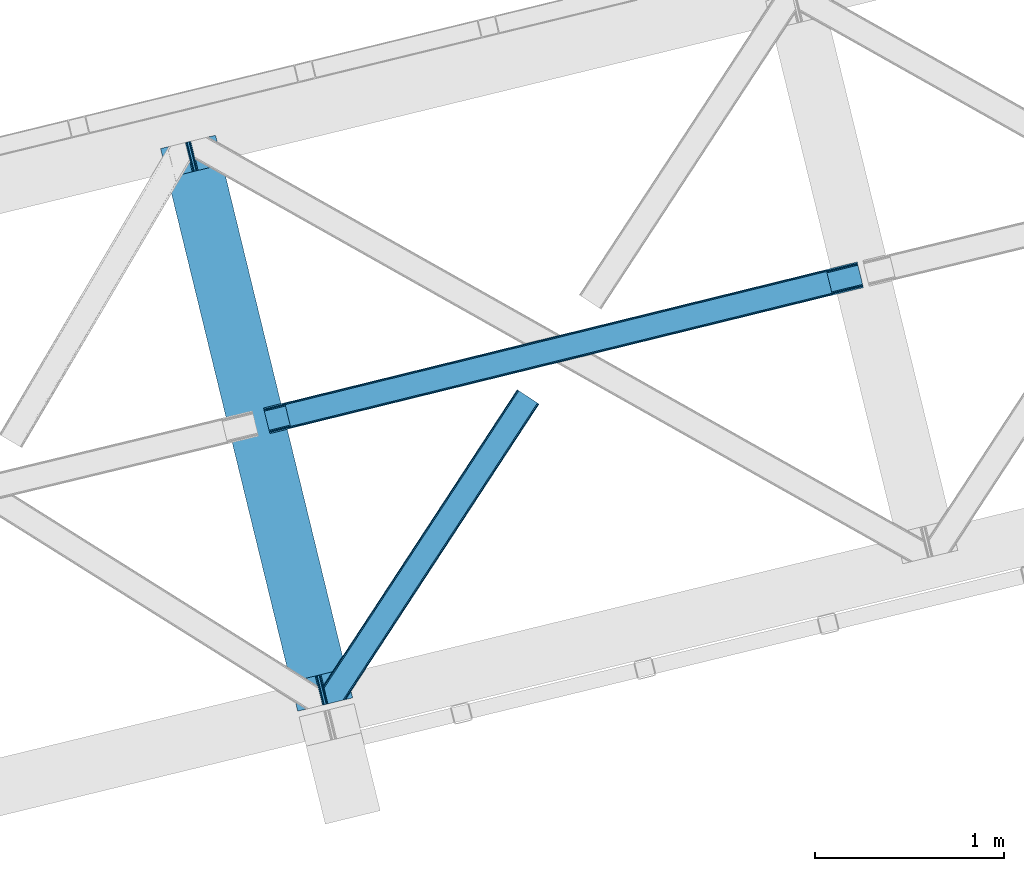
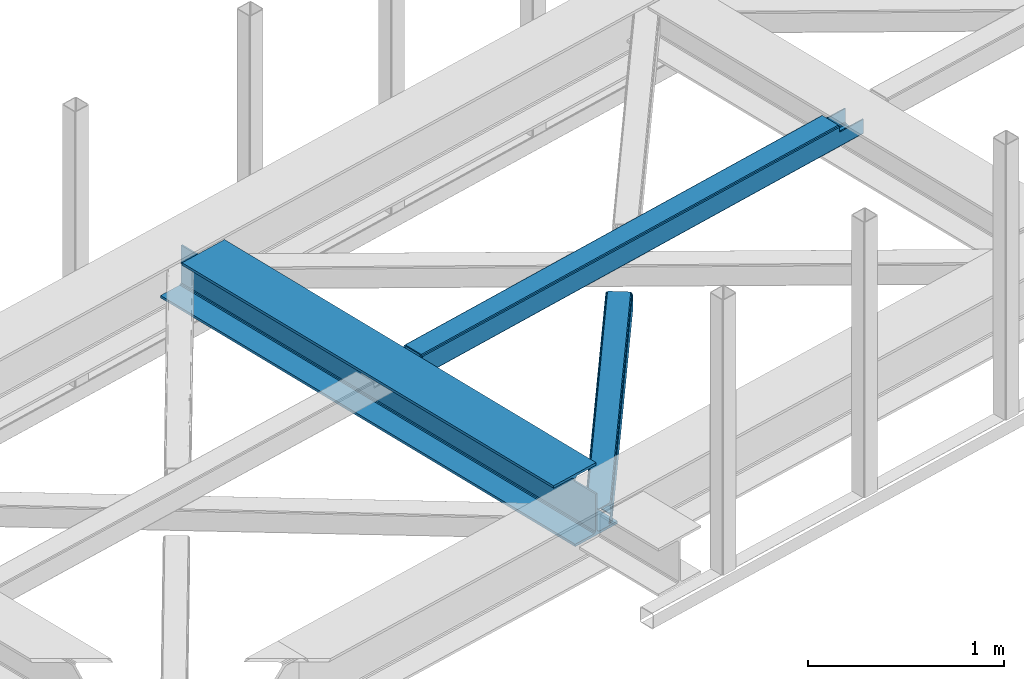
# One storey, part 25 of 67: 2 beams, 1 member.
"""IFC4 building model written with IfcOpenShell, lengths in millimetres."""

import ifcopenshell
import ifcopenshell.guid

model = None  # the IFC model being written
_history = None  # IfcOwnerHistory: only IFC2X3 demands one
_inside = {}  # id of a spatial element -> (the spatial element, [elements in it])
_under = {}  # id of a project, library or spatial element -> (it, [spatial elements below it])
_declared = {}  # id of a project -> (the project, [libraries it declares])
_typed = {}  # id of a type object -> (the type object, [elements of that type])
_made_of = {}  # id of a material, layer set ... -> (it, [elements and type objects made of it])


def new_model(schema):
    """Start an empty IFC model of exactly this schema.

    Asked for "IFC4X3", IfcOpenShell would pick the latest addendum, in which some entities
    have other attributes; the version numbers below select the first issue.
    IFC2X3 requires an IfcOwnerHistory on every rooted entity: one is made here for all.
    """
    global model, _history
    if schema == "IFC4X3":
        model = ifcopenshell.file(schema_version=(4, 3, 0, 0))
    else:
        model = ifcopenshell.file(schema=schema)
    _inside.clear()
    _under.clear()
    _declared.clear()
    _typed.clear()
    _made_of.clear()
    _history = None
    if model.schema == "IFC2X3":
        org = make("IfcOrganization", Name="unknown")
        user = make(
            "IfcPersonAndOrganization",
            ThePerson=make("IfcPerson", FamilyName="unknown"),
            TheOrganization=org,
        )
        app = make(
            "IfcApplication",
            ApplicationDeveloper=org,
            Version="unknown",
            ApplicationFullName="unknown",
            ApplicationIdentifier="unknown",
        )
        _history = make(
            "IfcOwnerHistory",
            OwningUser=user,
            OwningApplication=app,
            ChangeAction="ADDED",
            CreationDate=0,
        )
    return model


def make(cls, **values):
    """One entity of the class cls with the attributes given. An attribute that is None is left unset."""
    return model.create_entity(
        cls, **{name: value for name, value in values.items() if value is not None}
    )


def entity(cls, *values):
    """Any entity or typed value of the class cls, its attributes in the order of the schema. None: left unset."""
    e = model.create_entity(cls)
    for i, value in enumerate(values):
        if value is not None:
            e[i] = value
    return e


def rooted(cls, **values):
    """An entity with a GlobalId (a new one), such as an element, a storey or a relation."""
    return make(cls, GlobalId=ifcopenshell.guid.new(), OwnerHistory=_history, **values)


def si_unit(unit_type, name, prefix=None):
    """IfcSIUnit, for example si_unit("LENGTHUNIT", "METRE", prefix="MILLI")."""
    return make("IfcSIUnit", UnitType=unit_type, Prefix=prefix, Name=name)


def converted_unit(unit_type, name, factor, base, dimensions=None, offset=None):
    """IfcConversionBasedUnit, such as the inch: factor (a typed value) times the base unit."""
    return make(
        "IfcConversionBasedUnit"
        if offset is None
        else "IfcConversionBasedUnitWithOffset",
        ConversionOffset=offset,
        Dimensions=None
        if dimensions is None
        else entity("IfcDimensionalExponents", *dimensions),
        UnitType=unit_type,
        Name=name,
        ConversionFactor=make(
            "IfcMeasureWithUnit", ValueComponent=factor, UnitComponent=base
        ),
    )


def derived_unit(unit_type, elements):
    """IfcDerivedUnit: a product of units, each with its exponent."""
    return make(
        "IfcDerivedUnit",
        Elements=[
            make("IfcDerivedUnitElement", Unit=unit, Exponent=power)
            for unit, power in elements
        ],
        UnitType=unit_type,
    )


def assignment(units):
    """IfcUnitAssignment: the units of a project."""
    return None if units is None else make("IfcUnitAssignment", Units=units)


def point(xyz):
    """IfcCartesianPoint."""
    return None if xyz is None else make("IfcCartesianPoint", Coordinates=xyz)


def direction(xyz):
    """IfcDirection."""
    return None if xyz is None else make("IfcDirection", DirectionRatios=xyz)


def frame(location, z_axis=None, x_axis=None):
    """IfcAxis2Placement3D, a coordinate frame: its origin and axes. An axis left out is left unset."""
    return make(
        "IfcAxis2Placement3D",
        Location=point(location),
        Axis=direction(z_axis),
        RefDirection=direction(x_axis),
    )


def origin():
    """The frame at (0, 0, 0) with its axes left unset."""
    return frame((0.0, 0.0, 0.0))


def place(relative_to, where):
    """IfcLocalPlacement: puts the frame where relative to a parent placement (None: the world)."""
    return make(
        "IfcLocalPlacement", PlacementRelTo=relative_to, RelativePlacement=where
    )


def context(
    kind, dimensions, precision=None, world=None, true_north=None, identifier=None
):
    """IfcGeometricRepresentationContext, for example the 3D "Model" context."""
    return make(
        "IfcGeometricRepresentationContext",
        ContextIdentifier=identifier,
        ContextType=kind,
        CoordinateSpaceDimension=dimensions,
        Precision=precision,
        WorldCoordinateSystem=world,
        TrueNorth=true_north,
    )


def subcontext(parent, identifier, kind, view, scale=None):
    """IfcGeometricRepresentationSubContext, for example "Body" below "Model"."""
    return make(
        "IfcGeometricRepresentationSubContext",
        ContextIdentifier=identifier,
        ContextType=kind,
        ParentContext=parent,
        TargetScale=scale,
        TargetView=view,
    )


def project(units=None, contexts=None):
    """IfcProject with its units and contexts."""
    return rooted(
        "IfcProject",
        Name="project",
        RepresentationContexts=contexts,
        UnitsInContext=assignment(units),
    )


def spatial(cls, under=None, at=None, **own):
    """A site, building, storey or space (cls), placed at a placement, below another one or the project."""
    s = rooted(cls, ObjectPlacement=at, **own)
    if under is not None:
        _under.setdefault(under.id(), (under, []))[1].append(s)
    return s


def point_list(points):
    """IfcCartesianPointList2D or 3D."""
    cls = (
        "IfcCartesianPointList2D" if len(points[0]) == 2 else "IfcCartesianPointList3D"
    )
    return make(cls, CoordList=points)


def triangles(points, corners, closed=None, point_numbers=None):
    """IfcTriangulatedFaceSet: each triangle names its three corners, points numbered from 1."""
    return make(
        "IfcTriangulatedFaceSet",
        Coordinates=point_list(points),
        Closed=closed,
        CoordIndex=corners,
        PnIndex=point_numbers,
    )


def polygons(points, faces, closed=None, point_numbers=None):
    """IfcPolygonalFaceSet: a face is its outer loop, then its inner loops; points numbered from 1."""
    made = []
    for loops in faces:
        if len(loops) == 1:
            made.append(make("IfcIndexedPolygonalFace", CoordIndex=loops[0]))
        else:
            made.append(
                make(
                    "IfcIndexedPolygonalFaceWithVoids",
                    CoordIndex=loops[0],
                    InnerCoordIndices=loops[1:],
                )
            )
    return make(
        "IfcPolygonalFaceSet",
        Coordinates=point_list(points),
        Closed=closed,
        Faces=made,
        PnIndex=point_numbers,
    )


def shape(context_of_items, identifier, shape_type, items):
    """IfcShapeRepresentation: the items that make up one representation, for example the "Body"."""
    return make(
        "IfcShapeRepresentation",
        ContextOfItems=context_of_items,
        RepresentationIdentifier=identifier,
        RepresentationType=shape_type,
        Items=items,
    )


def material(Name=None, Category=None):
    """IfcMaterial."""
    return make("IfcMaterial", Name=Name, Category=Category)


def made_of(thing, what):
    """Note that an element or type object is made of a material, layer set ...; save() writes the relation."""
    if what is not None:
        _made_of.setdefault(what.id(), (what, []))[1].append(thing)
    return thing


def type_object(cls, material=None, **own):
    """A type object (cls), such as IfcWallType, which elements share."""
    return made_of(rooted(cls, **own), material)


def element(
    cls,
    number,
    at=None,
    inside=None,
    cuts=None,
    type_object=None,
    material=None,
    context=None,
    identifier="Body",
    shape_type=None,
    held_by="IfcProductDefinitionShape",
    body=None,
    shapes=None,
    **own,
):
    """One element of the class cls, such as IfcWall. Its Tag is "e" and its number.

    at: its placement. inside: the storey or other place that contains it. cuts: it is an
    opening in that element (IfcRelVoidsElement). A single representation is given by context,
    identifier, shape_type and body (its items); several are given by shapes. held_by: the class
    of the entity that holds the representations. save() writes the other relations.
    """
    e = rooted(cls, Tag="e%d" % number, ObjectPlacement=at, **own)
    if body is not None:
        shapes = [shape(context, identifier, shape_type, body)]
    if shapes is not None:
        e.Representation = make(held_by, Representations=shapes)
    if inside is not None:
        _inside.setdefault(inside.id(), (inside, []))[1].append(e)
    if cuts is not None:
        rooted(
            "IfcRelVoidsElement", RelatingBuildingElement=cuts, RelatedOpeningElement=e
        )
    if type_object is not None:
        _typed.setdefault(type_object.id(), (type_object, []))[1].append(e)
    return made_of(e, material)


def aggregate(whole, parts):
    """IfcRelAggregates: a whole, such as a stair, and the parts it consists of."""
    return rooted("IfcRelAggregates", RelatingObject=whole, RelatedObjects=parts)


def save(model, path):
    """Write the relations noted so far, then the file.

    IfcRelAggregates (storeys below a building ...), IfcRelContainedInSpatialStructure (elements
    in a storey), IfcRelDefinesByType, IfcRelAssociatesMaterial and IfcRelDeclares: one each for
    every whole, place, type object, material and project.
    """
    for whole, parts in _under.values():
        aggregate(whole, parts)
    for where, things in _inside.values():
        rooted(
            "IfcRelContainedInSpatialStructure",
            RelatedElements=things,
            RelatingStructure=where,
        )
    for kind, things in _typed.values():
        rooted("IfcRelDefinesByType", RelatedObjects=things, RelatingType=kind)
    for what, things in _made_of.values():
        rooted("IfcRelAssociatesMaterial", RelatedObjects=things, RelatingMaterial=what)
    for by, libraries in _declared.values():
        rooted("IfcRelDeclares", RelatingContext=by, RelatedDefinitions=libraries)
    model.write(path)


model = new_model("IFC4")

# Units and contexts
model_context = context("Model", 3, precision=0.01, world=origin(), true_north=direction((6.12303176911189e-17, 1.0)))
plan_context = context("Plan", 3, precision=0.01, world=origin(), true_north=direction((6.12303176911189e-17, 1.0)))
body_context = subcontext(model_context, "Body", "Model", "MODEL_VIEW")
ifc_project = project(units=[si_unit("LENGTHUNIT", "METRE", prefix="MILLI"), si_unit("AREAUNIT", "SQUARE_METRE"), si_unit("VOLUMEUNIT", "CUBIC_METRE"), converted_unit("PLANEANGLEUNIT", "DEGREE", entity("IfcRatioMeasure", 0.0174532925199433), si_unit("PLANEANGLEUNIT", "RADIAN"), dimensions=[0, 0, 0, 0, 0, 0, 0]), si_unit("MASSUNIT", "GRAM", prefix="KILO"), derived_unit("MASSDENSITYUNIT", [(si_unit("MASSUNIT", "GRAM", prefix="KILO"), 1), (si_unit("LENGTHUNIT", "METRE"), -3)]), derived_unit("MOMENTOFINERTIAUNIT", [(si_unit("LENGTHUNIT", "METRE"), 4)]), si_unit("TIMEUNIT", "SECOND"), si_unit("FREQUENCYUNIT", "HERTZ"), si_unit("THERMODYNAMICTEMPERATUREUNIT", "DEGREE_CELSIUS"), derived_unit("THERMALTRANSMITTANCEUNIT", [(si_unit("MASSUNIT", "GRAM", prefix="KILO"), 1), (si_unit("THERMODYNAMICTEMPERATUREUNIT", "KELVIN"), -1), (si_unit("TIMEUNIT", "SECOND"), -3)]), derived_unit("VOLUMETRICFLOWRATEUNIT", [(si_unit("LENGTHUNIT", "METRE"), 3), (si_unit("TIMEUNIT", "SECOND"), -1)]), derived_unit("MASSFLOWRATEUNIT", [(si_unit("MASSUNIT", "GRAM", prefix="KILO"), 1), (si_unit("TIMEUNIT", "SECOND"), -1)]), derived_unit("ROTATIONALFREQUENCYUNIT", [(si_unit("TIMEUNIT", "SECOND"), -1)]), si_unit("ELECTRICCURRENTUNIT", "AMPERE"), si_unit("ELECTRICVOLTAGEUNIT", "VOLT"), si_unit("POWERUNIT", "WATT"), si_unit("FORCEUNIT", "NEWTON", prefix="KILO"), si_unit("ILLUMINANCEUNIT", "LUX"), si_unit("LUMINOUSFLUXUNIT", "LUMEN"), si_unit("LUMINOUSINTENSITYUNIT", "CANDELA"), derived_unit("USERDEFINED", [(si_unit("MASSUNIT", "GRAM", prefix="KILO"), -1), (si_unit("LENGTHUNIT", "METRE"), -2), (si_unit("TIMEUNIT", "SECOND"), 3), (si_unit("LUMINOUSFLUXUNIT", "LUMEN"), 1)]), derived_unit("LINEARVELOCITYUNIT", [(si_unit("LENGTHUNIT", "METRE"), 1), (si_unit("TIMEUNIT", "SECOND"), -1)]), si_unit("PRESSUREUNIT", "PASCAL"), derived_unit("USERDEFINED", [(si_unit("LENGTHUNIT", "METRE"), -2), (si_unit("MASSUNIT", "GRAM", prefix="KILO"), 1), (si_unit("TIMEUNIT", "SECOND"), -2)]), derived_unit("LINEARFORCEUNIT", [(si_unit("MASSUNIT", "GRAM", prefix="KILO"), 1), (si_unit("LENGTHUNIT", "METRE"), 1), (si_unit("TIMEUNIT", "SECOND"), -2), (si_unit("LENGTHUNIT", "METRE"), -1)]), derived_unit("PLANARFORCEUNIT", [(si_unit("MASSUNIT", "GRAM", prefix="KILO"), 1), (si_unit("LENGTHUNIT", "METRE"), 1), (si_unit("TIMEUNIT", "SECOND"), -2), (si_unit("LENGTHUNIT", "METRE"), -2)])], contexts=[model_context, plan_context])

# Site, building, storey
site_placement = place(None, origin())
site = spatial("IfcSite", under=ifc_project, at=site_placement, CompositionType="ELEMENT")
building_placement = place(site_placement, origin())
building = spatial("IfcBuilding", under=site, at=building_placement, CompositionType="ELEMENT")
storey_placement = place(building_placement, frame((0.0, 0.0, 19800.0)))
storey = spatial("IfcBuildingStorey", under=building, at=storey_placement, CompositionType="ELEMENT", Elevation=19800.0)

# Beams
ifc_material = material(Name="Metal painted (White)")
beam_type = type_object("IfcBeamType", PredefinedType="BEAM")
beam_1_placement = place(storey_placement, frame((-49493.1827981071, 5730.44227805127, 3808.0)))
element("IfcBeam", 1, at=beam_1_placement, inside=storey, type_object=beam_type, material=ifc_material, ObjectType="Steel Beam", PredefinedType="BEAM", context=body_context, shape_type="Tessellation", body=[
    polygons([(1018.16648378331, 71.0478278971021, 15.5000000000051), (1018.16648378331, 71.0478278971021, 0.0), (291.465617442455, 3052.25531830421, 0.0), (291.465617442464, 3052.25531830421, 15.5000000000051), (894.779372399346, 40.9709140873291, 15.5000000000051), (168.078506058491, 3022.17840449444, 15.5000000000051), (888.087028625375, 39.3395844888232, 16.8701684148028), (161.386162284528, 3020.54707489594, 16.8701684148028), (882.413533524759, 37.9566100336519, 20.7720779386478), (155.712667183921, 3019.16410044076, 20.7720779386478), (878.622625296184, 37.0325360459173, 26.6116982174338), (151.921758955338, 3018.24002645303, 26.6116982174338), (877.291435352796, 36.7080444135029, 33.500000000001), (150.590569011932, 3017.91553482062, 33.500000000001), (140.875048430522, 3015.54727389071, 33.500000000001), (140.875048430531, 3015.54727389071, 259.000000000006), (150.590569011932, 3017.91553482062, 259.000000000006), (0.0, 2981.20749040711, 4.33146851719357e-12), (8.66293703438714e-12, 2981.20749040711, 15.5000000000051), (123.387111383972, 3011.28440421688, 15.5000000000051), (130.079455157926, 3012.91573381539, 16.8701684148028), (135.752950258551, 3014.29870827056, 20.7720779386478), (139.543858487126, 3015.2227822583, 26.6116982174338), (877.291435352788, 36.7080444135029, 259.000000000006), (867.575914771378, 34.3397834835992, 259.000000000006), (867.575914771378, 34.3397834836003, 33.500000000001), (866.244724827981, 34.0152918511837, 26.6116982174338), (862.453816599406, 33.0912178634492, 20.7720779386478), (856.780321498782, 31.7082434082778, 16.8701684148028), (850.087977724828, 30.076913809773, 15.5000000000051), (726.700866340855, 0.0, 15.5000000000051), (726.700866340855, 0.0, 4.33146851719357e-12), (839.723099725422, 190.827961666227, 259.069792599954), (188.068298227665, 2864.16742161973, 259.000000000006), (188.291691329505, 2863.25097721476, 259.617303331129), (188.304080173139, 2863.20015298098, 266.500003008253), (839.577920935832, 191.42343960925, 266.500002998871), (839.578271056585, 191.422003304516, 260.000004007593), (830.09816248951, 188.087889491627, 259.00634317046), (829.874792453813, 189.004341089457, 259.617303331129), (829.862403610171, 189.055165323231, 266.500003008253), (178.588562847478, 2860.83187869496, 266.500002998871), (178.588212726726, 2860.8333149997, 260.000004007593), (178.44340706839, 2861.42736381349, 259.076120467494), (178.352777646246, 2861.79916068982, 259.000000000006), (840.90940880576, 191.746709053934, 273.388305639792), (844.699685394456, 192.673374225848, 279.227924098781), (850.372756341994, 194.058088689525, 283.129832400619), (857.064948023119, 195.690042220338, 284.500000377228), (980.451976710963, 225.767295275449, 284.500000138975), (980.450306904311, 225.774145344181, 299.999995328161), (688.984884807032, 154.725516080138, 299.999995890966), (688.986554613684, 154.718666011407, 284.500000701776), (812.373583301537, 184.795919066518, 284.500000463524), (819.066070197675, 186.426661533096, 283.129832461069), (824.739981846436, 187.807927177622, 279.227924137327), (828.531516633427, 188.72943082692, 273.388305663689), (177.257074977542, 2860.50860925028, 273.388305639792), (173.466798388855, 2859.58194407836, 279.227924098781), (167.793727441316, 2858.19722961469, 283.129832400619), (161.101535760191, 2856.56527608387, 284.500000377228), (37.7145070723384, 2826.48802302876, 284.500000138975), (37.7161768790075, 2826.48117296003, 299.999995328161), (329.181598976278, 2897.52980222407, 299.999995890962), (329.179929169617, 2897.53665229281, 284.500000701776), (205.792900481773, 2867.4593992377, 284.500000463524), (199.100413585635, 2865.82865677112, 283.129832461069), (193.426501936874, 2864.44739112659, 279.227924137327), (189.634967149883, 2863.52588747729, 273.388305663689)], [[[1, 2, 3, 4]], [[5, 1, 4, 6]], [[7, 5, 6, 8]], [[9, 7, 8, 10]], [[11, 9, 10, 12]], [[13, 11, 12, 14]], [[15, 16, 17, 14, 12, 10, 8, 6, 4, 3, 18, 19, 20, 21, 22, 23]], [[13, 24, 25, 26, 27, 28, 29, 30, 31, 32, 2, 1, 5, 7, 9, 11]], [[2, 32, 18, 3]], [[32, 31, 19, 18]], [[31, 30, 20, 19]], [[27, 26, 15, 23]], [[28, 27, 23, 22]], [[29, 28, 22, 21]], [[30, 29, 21, 20]], [[33, 24, 13, 14, 17, 34, 35, 36, 37, 38]], [[25, 39, 40, 41, 42, 43, 44, 16, 15, 26]], [[39, 25, 24, 33]], [[45, 34, 17, 16]], [[41, 40, 38, 37, 46, 47, 48, 49, 50, 51, 52, 53, 54, 55, 56, 57]], [[42, 58, 59, 60, 61, 62, 63, 64, 65, 66, 67, 68, 69, 36, 35, 43]], [[46, 37, 36, 69]], [[47, 46, 69, 68]], [[48, 47, 68, 67]], [[49, 48, 67, 66]], [[50, 49, 66, 65]], [[51, 50, 65, 64]], [[52, 51, 64, 63]], [[53, 52, 63, 62]], [[54, 53, 62, 61]], [[55, 54, 61, 60]], [[56, 55, 60, 59]], [[57, 56, 59, 58]], [[41, 57, 58, 42]]], closed=False),
])
beam_2_placement = place(storey_placement, frame((-48947.5958701554, 7201.56949644278, 3967.02199604692)))
element("IfcBeam", 2, at=beam_2_placement, inside=storey, type_object=beam_type, material=ifc_material, ObjectType="Steel Beam", PredefinedType="BEAM", context=body_context, shape_type="Tessellation", body=[
    polygons([(3014.66198685415, 733.277520458038, 122.551106515378), (3014.34650819573, 734.571735702759, 129.24806605045), (144.865809052569, 28.7790637903131, 130.140231320828), (145.18128771098, 27.4848485456453, 123.443271785764), (3013.44810098643, 738.257348897747, 134.92547253129), (143.967401843277, 32.4646769852602, 135.817637801681), (3012.10353957978, 743.773258844291, 138.718992287022), (142.622840436624, 37.9805869318079, 139.611157557409), (3010.51752126149, 750.279718254773, 140.051096323177), (141.036822118309, 44.4870463424154, 140.943261593568), (2985.65072770548, 852.292905035273, 140.051030384396), (116.1700285623, 146.50023312292, 140.943195654778), (2984.06470938713, 858.79936444598, 138.71891793701), (114.584010243976, 153.006692533531, 139.611083207401), (2982.72014798048, 864.315274392527, 134.92539105058), (113.239448837332, 158.522602480079, 135.817556320971), (2981.8217407712, 868.000887587489, 129.247979805159), (112.341041628031, 162.208215675055, 130.14014507555), (2981.50626211281, 869.295102832038, 122.551018597005), (112.025562969637, 163.502430919657, 123.443183867375), (113.683357408731, 156.701518153041, 116.478003953074), (113.998827865116, 155.407336556291, 123.140149152425), (114.897235074409, 151.721723361319, 128.817560397855), (116.241796481061, 146.205813414771, 132.611087284285), (117.827814799368, 139.699354004221, 133.943199731657), (139.37903588124, 51.2879254611191, 133.943256878606), (140.965054199582, 44.7814660504163, 132.611152842451), (142.309615606234, 39.2655561038664, 128.817633086723), (143.208022815527, 35.5799429088976, 123.140226605874), (143.523493309154, 34.2857611593384, 116.478003953074), (145.18128771098, 27.4848485456616, 116.47800395307), (112.025562969637, 163.502430919668, 116.47800395307), (2981.50626211281, 869.295102832025, 100.498227844497), (3014.66198685415, 733.277520458023, 100.498227844497), (3013.00420052616, 740.078399946393, 100.498227844497), (3013.00420061709, 740.078399576723, 115.551101800424), (3012.68872195868, 741.372614821346, 122.248061335492), (3011.79031474938, 745.058228016315, 127.925467816341), (3010.44575334274, 750.574137962861, 131.718987572073), (3008.85973502442, 757.080597373472, 133.051091608228), (2987.30851394254, 845.492025916574, 133.051034461284), (2985.72249562422, 851.998485327185, 131.718922013898), (2984.37793421758, 857.514395273731, 127.925395127473), (2983.47952700828, 861.200008468702, 122.247983882047), (2983.16404849861, 862.494223108653, 115.551022673885), (2983.16404834987, 862.494223713326, 100.498227844497), (143.616995693866, 27.1000869952791, 112.588916656551), (142.052703676727, 26.7153254450113, 108.699829360001), (138.276168673461, 25.7864288919117, 107.08891665653), (134.499633670186, 24.857532338875, 105.478003953059), (33.4640040774262, 0.0062737156981143, 105.478003953085), (33.4384975699194, 9.74580416368554e-12, 18.478009536212), (3178.77103529923, 773.642651271288, 17.5000777261801), (3178.77103529923, 773.642651271288, 99.498227844506), (3015.63304631242, 733.516367385914, 99.4982278445016), (8.66293703438714e-12, 135.948030071304, 18.478009536212), (0.0255065074981076, 135.95430378699, 105.478003953085), (101.343908928827, 160.875114712881, 105.478003953085), (105.12044393211, 161.804011265932, 107.088916656556), (108.896978935376, 162.732907819021, 108.699829360019), (110.461270952515, 163.117669369314, 112.588916656546), (3145.61531055789, 909.660233645289, 99.4982278445016), (3145.6153105579, 909.660233645289, 17.4999898077994), (136.618382436393, 32.5873080105591, 107.088916656582), (132.841847009942, 31.6584131779827, 105.478003953103), (140.394917439667, 33.5162045636273, 108.69982936004), (141.96566168455, 33.9025531380652, 112.587584068376), (112.125526157786, 156.318372488323, 112.587581008938), (110.554765172462, 155.93202870027, 108.699829360001), (106.778230169196, 155.003132147206, 107.088916656504), (103.001695695356, 154.074233441606, 105.478003953051), (31.7920783309542, 6.8036787481157, 105.478003953085), (3177.11324895927, 780.443530808336, 99.498227844506), (3177.11324963609, 780.44352805663, 24.5000736492964), (31.7686248297565, 6.79790673020325, 25.4780092171761), (1.69743247226747, 129.156897867046, 105.478003953085), (1.67397729591764, 129.151132659746, 25.4780092171761), (3147.27309610399, 902.859357335771, 24.4999945227572), (3147.27309696331, 902.85935384209, 99.498227844506), (2984.13510802055, 862.733069777618, 99.4982278444973), (3013.97526007535, 740.317246504614, 99.498227844506), (2982.47732157107, 869.533949759916, 99.4982278445016), (3147.58857545337, 901.565139281965, 17.8030349876851), (3148.48698266265, 897.879526086999, 12.125628506845), (3149.8315440693, 892.363616140453, 8.33210875111238), (3151.41756238762, 885.857156729842, 7.00000471495782), (3172.96878346949, 797.445728186741, 7.00006186190616), (3174.55480178782, 790.93926877613, 8.33217430928745), (3175.89936319447, 785.423358829583, 12.1257011957087), (3176.79777040376, 781.737745634615, 17.8031124411339), (3178.45555664086, 774.936866515781, 10.8031165180479), (3177.55714943157, 778.622479710752, 5.12570527262277), (3176.21258802492, 784.1383896573, 1.33217838619282), (3174.62656970656, 790.644849068041, 6.59387855421301e-05), (3149.75977615055, 892.658035848542, 4.33146851719357e-12), (3148.17375783225, 899.164495259058, 1.33210403618054), (3146.82919642561, 904.680405205607, 5.12562379191745), (3145.93078921631, 908.366018400585, 10.8030302727576), (31.4484922777377, 8.09097680671073, 18.78104945601), (30.5407583952027, 11.7742959637272, 13.1036411103947), (29.1836175465794, 17.2871118040927, 9.31011813510754), (27.5836821235256, 23.7901480899073, 7.97801001476801), (4.24950437033222, 118.659596043167, 9.31011813510754), (5.84865870308149, 112.156367636244, 7.97801001476368), (2.89458787866886, 124.172958998151, 13.1036411103947), (1.99018298160754, 127.857096970068, 18.78104945601), (0.316205855336193, 134.653993691895, 11.7810497750459), (1.22061075240617, 130.969855719986, 6.10364142943058), (2.57552724406953, 125.456492764999, 2.31011845414345), (4.17468157681881, 118.953264358077, 0.97801033379958), (29.2535547542584, 16.992241804612, 0.978010333803911), (30.8534901773035, 10.4892055187962, 2.31011845414345), (32.2106310259441, 4.97638967843289, 6.10364142943058), (33.1183649084791, 1.29307052141644, 11.7810497750415)], [[[1, 2, 3, 4]], [[2, 5, 6, 3]], [[5, 7, 8, 6]], [[7, 9, 10, 8]], [[11, 12, 10, 9]], [[11, 13, 14, 12]], [[13, 15, 16, 14]], [[15, 17, 18, 16]], [[17, 19, 20, 18]], [[21, 22, 23, 24, 25, 26, 27, 28, 29, 30, 31, 4, 3, 6, 8, 10, 12, 14, 16, 18, 20, 32]], [[33, 19, 17, 15, 13, 11, 9, 7, 5, 2, 1, 34, 35, 36, 37, 38, 39, 40, 41, 42, 43, 44, 45, 46]], [[26, 25, 41, 40]], [[40, 39, 27, 26]], [[39, 38, 28, 27]], [[38, 37, 29, 28]], [[37, 30, 29]], [[36, 30, 37]], [[25, 24, 42, 41]], [[24, 23, 43, 42]], [[23, 22, 44, 43]], [[44, 21, 45]], [[21, 44, 22]], [[47, 48, 49, 50, 51, 52, 53, 54, 55, 1, 4, 31]], [[56, 57, 58, 59, 60, 61, 32, 20, 19, 33, 62, 63]], [[50, 49, 64, 65]], [[49, 48, 66, 64]], [[66, 47, 67]], [[47, 30, 67]], [[30, 47, 31]], [[47, 66, 48]], [[68, 60, 69]], [[60, 59, 70, 69]], [[59, 58, 71, 70]], [[60, 68, 61]], [[61, 21, 32]], [[21, 61, 68]], [[72, 65, 64, 66, 67, 30, 36, 35, 73, 74, 75]], [[71, 76, 77, 78, 79, 80, 45, 21, 68, 69, 70]], [[55, 54, 73, 81]], [[62, 82, 80, 79]], [[63, 62, 79, 78, 83, 84, 85, 86, 87, 88, 89, 90, 74, 73, 54, 53, 91, 92, 93, 94, 95, 96, 97, 98]], [[57, 76, 71, 58]], [[50, 65, 72, 51]], [[74, 90, 99, 75]], [[90, 89, 100, 99]], [[89, 88, 101, 100]], [[88, 87, 102, 101]], [[86, 85, 103, 104]], [[85, 84, 105, 103]], [[84, 83, 106, 105]], [[83, 78, 77, 106]], [[102, 87, 86, 104]], [[52, 51, 72, 75, 99, 100, 101, 102, 104, 103, 105, 106, 77, 76, 57, 56, 107, 108, 109, 110, 111, 112, 113, 114]], [[94, 93, 112, 111]], [[93, 92, 113, 112]], [[92, 91, 114, 113]], [[91, 53, 52, 114]], [[63, 98, 107, 56]], [[98, 97, 108, 107]], [[97, 96, 109, 108]], [[96, 95, 110, 109]], [[95, 94, 111, 110]]], closed=False),
])

# Member
member_type = type_object("IfcMemberType", PredefinedType="BRACE")
member_placement = place(storey_placement, frame((-48630.0642333984, 5769.51876525879, 3823.99987792968)))
element("IfcMember", 3, at=member_placement, inside=storey, type_object=member_type, ObjectType="Steel Horizontal Brace", PredefinedType="BRACE", context=body_context, shape_type="Tessellation", body=[
    triangles([(109.770043945311, 259.949830627442, 7.52047119140843), (115.030187988275, 238.365682983398, 7.77626953125218), (114.216284179682, 239.94640045166, 8.3320495605476), (108.807312011719, 259.662057495118, 8.52041015625218), (113.6349243164, 239.859777832031, 8.52041015625218), (112.207104492183, 237.677352905273, 8.52041015625218), (91.0363037109346, 232.516621398926, 8.52041015625218), (109.532849121089, 237.025648498535, 9.49942016601563), (90.2596069335923, 232.32767944336, 9.49942016601563), (5.01829833984084, 77.405158996582, 9.49942016601563), (0.62786865234375, 95.4308029174808, 9.49942016601563), (1046.62448730468, 1651.75324859619, 6.99957275390625), (1041.02017822265, 1655.42221069336, 8.3320495605476), (116.699853515624, 231.514356994629, 6.99957275390625), (1036.27163085937, 1658.53190460205, 12.1248413085959), (3.92999267578125, 81.8752349853512, 12.1248413085959), (1033.0950805664, 1660.61026611328, 17.8035644531265), (2.70216064452688, 86.9220199584961, 17.8035644531265), (1031.98352050781, 1661.3398727417, 24.5008300781265), (2.26962890624418, 88.6940048217775, 24.5008300781265), (1122.75472412109, 1601.90454711914, 6.99957275390625), (146.20968017578, 110.458955383301, 6.99957275390625), (1031.98352050781, 1661.3398727417, 115.499926757813), (2.26962890624418, 88.6940048217775, 115.499926757813), (1033.0950805664, 1660.61026611328, 122.197192382813), (2.70216064452688, 86.9220199584961, 122.197192382813), (1036.27163085937, 1658.53190460205, 127.873590087893), (3.92999267578125, 81.8752349853512, 127.873590087893), (1041.02017822265, 1655.42221069336, 131.668707275392), (5.77174072265188, 74.322789001465, 131.668707275392), (1046.62448730468, 1651.75324859619, 133.001184082033), (7.94370117186918, 65.4140304565426, 133.001184082033), (1027.23962402344, 1664.44433441162, 10.8039916992202), (0.520898437498545, 95.8714736938473, 10.8691040039084), (0.0, 98.0056457519531, 17.5012573242202), (1035.16472167968, 1659.2562789917, 1.33247680664135), (112.258264160155, 249.73533782959, 1.33247680664135), (110.542089843744, 256.771536254882, 5.59500732422021), (109.077062988275, 259.839372253418, 8.32042236328198), (1030.4161743164, 1662.36655426025, 5.12526855468968), (1040.76903076172, 1655.58789825439, 0.0), (114.430224609372, 240.826579284668, 0.0), (1026.12806396484, 1665.1745223999, 17.5012573242202), (1128.61018066406, 1598.06989746094, 0.0), (148.479309082031, 101.147314453125, 0.0), (150.651269531249, 92.2385559082031, 1.33247680664135), (148.507214355464, 101.029298400879, 8.49948120117188), (152.488366699217, 84.686109924316, 5.12526855468968), (153.344128417964, 81.1822540283201, 8.49948120117188), (1026.12806396484, 1665.1745223999, 122.499499511719), (0.0, 98.0056457519531, 122.499499511719), (1040.76903076172, 1655.58789825439, 140.00075683594), (1035.16472167968, 1659.2562789917, 138.668280029298), (3.50211181640043, 83.6350112915043, 138.668280029298), (5.674072265625, 74.7262527465818, 140.00075683594), (1030.4161743164, 1662.36655426025, 134.87548828125), (1.66036376952979, 91.1874572753904, 134.87548828125), (1027.23962402344, 1664.44433441162, 129.196765136719), (0.432531738275429, 96.2336608886717, 129.196765136719), (23.8869140624956, 0.0, 140.00075683594), (23.8869140624956, 0.0, 133.001184082033), (1128.61018066406, 1598.06989746094, 140.00075683594), (93.3338378906192, 16.9280364990236, 140.00075683594), (1122.75472412109, 1601.90454711914, 133.001184082033), (83.3763061523423, 14.5008590698244, 133.001184082033), (1143.25114746093, 1588.48385467529, 122.499499511719), (1142.13958740234, 1589.21346130371, 129.196765136719), (118.225341796875, 22.9951080322262, 122.499499511719), (116.327783203124, 22.5335083007813, 129.196765136719), (1138.96303710937, 1591.29182281494, 134.87548828125), (110.932763671874, 21.2184722900392, 134.87548828125), (1134.21448974609, 1594.4020980835, 138.668280029298), (102.858837890621, 19.2499877929686, 138.668280029298), (1143.25114746093, 1588.48385467529, 17.5012573242202), (118.225341796875, 22.9951080322262, 17.5012573242202), (1142.13958740234, 1589.21346130371, 10.8039916992202), (1133.1075805664, 1595.12647247314, 12.1248413085959), (1136.27947998047, 1593.04811096191, 17.8035644531265), (1137.39569091797, 1592.3185043335, 24.5008300781265), (1138.96303710937, 1591.29182281494, 5.12526855468968), (1134.21448974609, 1594.4020980835, 1.33247680664135), (1128.35903320312, 1598.23616638184, 8.3320495605476), (1133.1075805664, 1595.12647247314, 127.873590087893), (1137.39569091797, 1592.3185043335, 115.499926757813), (1136.27947998047, 1593.04811096191, 122.197192382813), (1128.35903320312, 1598.23616638184, 131.668707275392), (92.9013061523438, 16.8228103637693, 131.668707275392), (100.979882812499, 18.79129486084, 127.873590087893), (106.374902343749, 20.106330871582, 122.197192382813), (108.267810058591, 20.5685119628906, 115.499926757813), (108.267810058591, 20.5685119628906, 24.5008300781265), (100.979882812499, 18.79129486084, 12.1248413085959), (115.472021484369, 22.32421875, 9.49942016601563), (106.374902343749, 20.106330871582, 17.8035644531265), (96.1987792968721, 17.6262496948239, 9.49942016601563), (115.941760253903, 22.4393280029299, 10.8691040039084), (153.060424804688, 80.2392883300781, 8.99945068359375), (152.776721191403, 79.2969039916989, 9.49942016601563), (148.711853027344, 99.8677413940432, 8.8831787109375), (148.600231933589, 99.023606872559, 9.08781738281323), (148.493261718744, 98.1672637939455, 9.2947814941399), (148.381640624997, 97.3225479125977, 9.49942016601563)], [[1, 2, 3], [4, 5, 6], [6, 7, 4], [7, 6, 8], [8, 9, 7], [9, 8, 10], [10, 11, 9], [12, 13, 3], [3, 2, 12], [2, 14, 12], [15, 16, 8], [8, 13, 15], [8, 5, 13], [16, 10, 8], [8, 6, 5], [15, 17, 18], [18, 16, 15], [17, 19, 20], [20, 18, 17], [21, 12, 14], [14, 22, 21], [19, 23, 20], [24, 20, 23], [23, 25, 24], [26, 24, 25], [25, 27, 26], [28, 26, 27], [27, 29, 28], [30, 28, 29], [29, 31, 30], [32, 30, 31], [33, 34, 35], [36, 37, 38], [33, 4, 9], [33, 1, 39], [9, 34, 33], [9, 11, 34], [4, 7, 9], [40, 38, 1], [1, 33, 40], [38, 40, 36], [36, 41, 37], [42, 37, 41], [35, 43, 33], [41, 44, 42], [45, 42, 44], [14, 42, 22], [37, 2, 38], [2, 37, 42], [38, 2, 1], [42, 14, 2], [22, 42, 45], [46, 47, 45], [47, 46, 48], [45, 47, 22], [48, 49, 47], [50, 43, 51], [35, 51, 43], [52, 53, 54], [54, 55, 52], [53, 56, 57], [57, 54, 53], [56, 58, 59], [59, 57, 56], [58, 50, 51], [51, 59, 58], [28, 57, 26], [30, 32, 55], [32, 60, 55], [32, 61, 60], [54, 30, 55], [28, 54, 57], [16, 11, 10], [28, 30, 54], [51, 35, 20], [24, 26, 51], [24, 51, 20], [57, 59, 26], [26, 59, 51], [35, 18, 20], [18, 11, 16], [11, 18, 34], [35, 34, 18], [62, 55, 63], [62, 52, 55], [55, 60, 63], [64, 32, 31], [32, 64, 65], [61, 32, 65], [66, 67, 68], [69, 68, 67], [67, 70, 69], [71, 69, 70], [70, 72, 71], [73, 71, 72], [72, 62, 73], [63, 73, 62], [74, 66, 75], [68, 75, 66], [76, 77, 78], [79, 66, 74], [76, 78, 74], [76, 80, 77], [78, 79, 74], [77, 80, 81], [21, 44, 41], [44, 82, 81], [82, 44, 21], [82, 77, 81], [67, 83, 70], [84, 66, 79], [66, 85, 67], [85, 66, 84], [67, 85, 83], [62, 64, 52], [72, 70, 83], [83, 86, 72], [86, 64, 62], [62, 72, 86], [15, 36, 40], [41, 12, 21], [41, 13, 12], [13, 41, 36], [15, 13, 36], [19, 43, 50], [33, 17, 15], [40, 33, 15], [17, 33, 43], [19, 17, 43], [53, 27, 56], [52, 64, 31], [31, 29, 52], [29, 27, 53], [53, 52, 29], [58, 56, 27], [50, 23, 19], [25, 50, 58], [50, 25, 23], [25, 58, 27], [64, 86, 87], [87, 65, 64], [86, 83, 88], [88, 87, 86], [83, 85, 89], [89, 88, 83], [85, 84, 90], [90, 89, 85], [84, 79, 90], [91, 90, 79], [89, 68, 69], [87, 73, 63], [60, 65, 63], [65, 60, 61], [65, 87, 63], [88, 73, 87], [88, 89, 71], [71, 73, 88], [69, 71, 89], [91, 75, 68], [92, 93, 94], [89, 90, 68], [92, 95, 93], [91, 94, 75], [90, 91, 68], [96, 75, 94], [94, 93, 96], [76, 74, 75], [49, 80, 97], [98, 97, 80], [49, 48, 80], [76, 96, 98], [98, 80, 76], [96, 93, 98], [44, 81, 45], [46, 45, 81], [81, 80, 46], [48, 46, 80], [75, 96, 76], [82, 21, 22], [77, 82, 47], [47, 99, 77], [77, 100, 101], [100, 77, 99], [101, 102, 77], [77, 102, 92], [95, 92, 102], [22, 47, 82], [79, 78, 91], [94, 91, 78], [78, 77, 94], [92, 94, 77], [102, 101, 98], [101, 100, 97], [100, 99, 49], [99, 47, 49], [102, 98, 93], [93, 95, 102]]),
])

save(model, "model.ifc")
